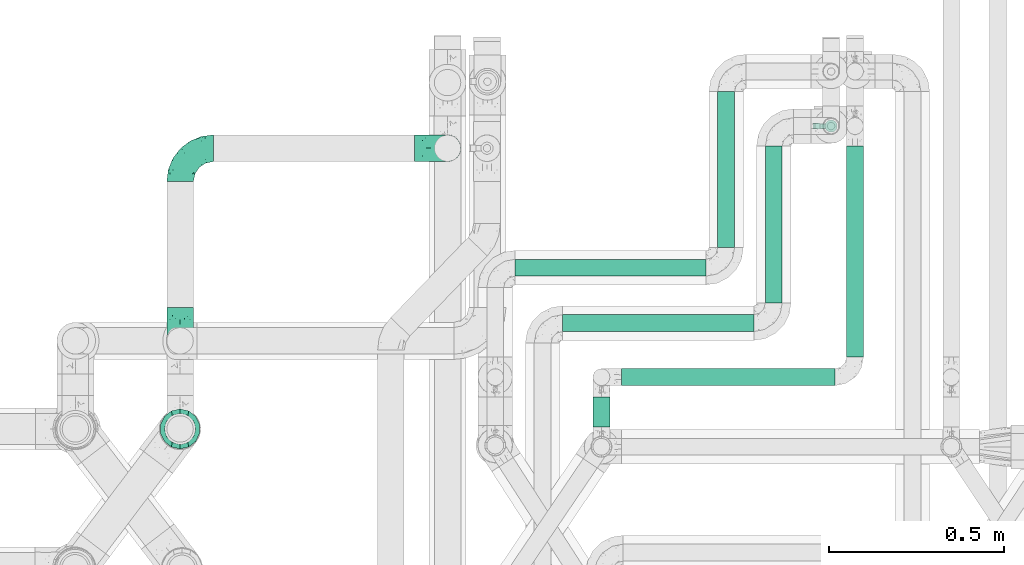
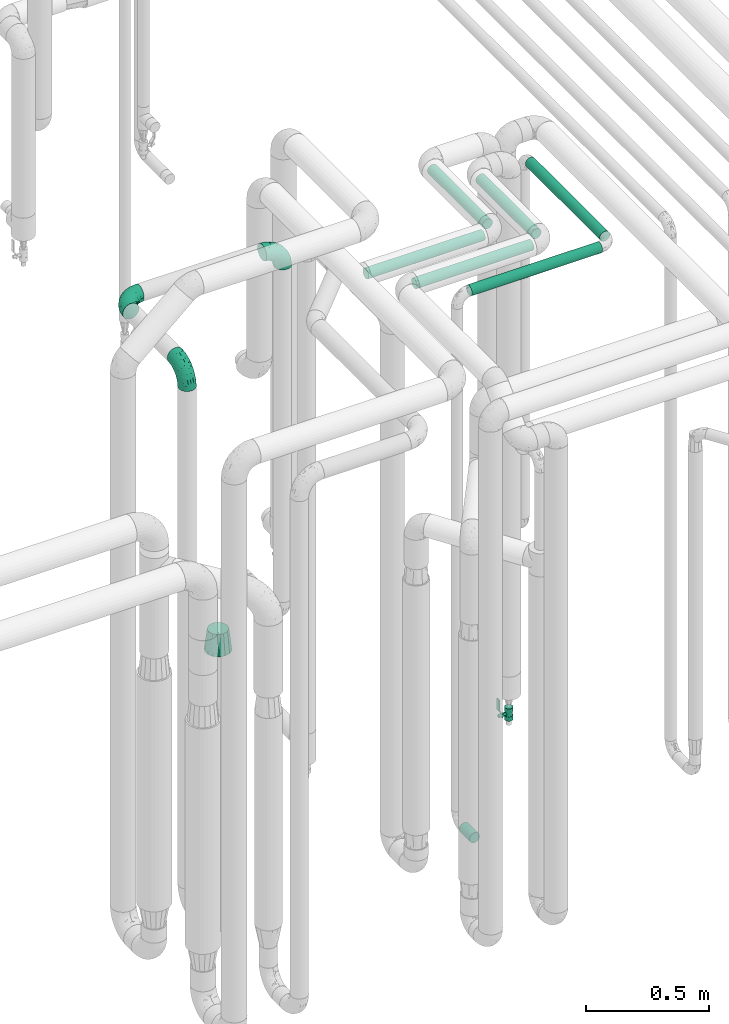
# One storey, part 673 of 827: 7 flow segments, 4 flow fittings, 1 flow controller.
"""IFC2X3 building model written with IfcOpenShell, lengths in millimetres."""

import ifcopenshell
import ifcopenshell.guid

model = None  # the IFC model being written
_history = None  # IfcOwnerHistory: only IFC2X3 demands one
_inside = {}  # id of a spatial element -> (the spatial element, [elements in it])
_under = {}  # id of a project, library or spatial element -> (it, [spatial elements below it])
_declared = {}  # id of a project -> (the project, [libraries it declares])
_typed = {}  # id of a type object -> (the type object, [elements of that type])
_made_of = {}  # id of a material, layer set ... -> (it, [elements and type objects made of it])


def new_model(schema):
    """Start an empty IFC model of exactly this schema.

    Asked for "IFC4X3", IfcOpenShell would pick the latest addendum, in which some entities
    have other attributes; the version numbers below select the first issue.
    IFC2X3 requires an IfcOwnerHistory on every rooted entity: one is made here for all.
    """
    global model, _history
    if schema == "IFC4X3":
        model = ifcopenshell.file(schema_version=(4, 3, 0, 0))
    else:
        model = ifcopenshell.file(schema=schema)
    _inside.clear()
    _under.clear()
    _declared.clear()
    _typed.clear()
    _made_of.clear()
    _history = None
    if model.schema == "IFC2X3":
        org = make("IfcOrganization", Name="unknown")
        user = make(
            "IfcPersonAndOrganization",
            ThePerson=make("IfcPerson", FamilyName="unknown"),
            TheOrganization=org,
        )
        app = make(
            "IfcApplication",
            ApplicationDeveloper=org,
            Version="unknown",
            ApplicationFullName="unknown",
            ApplicationIdentifier="unknown",
        )
        _history = make(
            "IfcOwnerHistory",
            OwningUser=user,
            OwningApplication=app,
            ChangeAction="ADDED",
            CreationDate=0,
        )
    return model


def make(cls, **values):
    """One entity of the class cls with the attributes given. An attribute that is None is left unset."""
    return model.create_entity(
        cls, **{name: value for name, value in values.items() if value is not None}
    )


def entity(cls, *values):
    """Any entity or typed value of the class cls, its attributes in the order of the schema. None: left unset."""
    e = model.create_entity(cls)
    for i, value in enumerate(values):
        if value is not None:
            e[i] = value
    return e


def rooted(cls, **values):
    """An entity with a GlobalId (a new one), such as an element, a storey or a relation."""
    return make(cls, GlobalId=ifcopenshell.guid.new(), OwnerHistory=_history, **values)


def si_unit(unit_type, name, prefix=None):
    """IfcSIUnit, for example si_unit("LENGTHUNIT", "METRE", prefix="MILLI")."""
    return make("IfcSIUnit", UnitType=unit_type, Prefix=prefix, Name=name)


def converted_unit(unit_type, name, factor, base, dimensions=None, offset=None):
    """IfcConversionBasedUnit, such as the inch: factor (a typed value) times the base unit."""
    return make(
        "IfcConversionBasedUnit"
        if offset is None
        else "IfcConversionBasedUnitWithOffset",
        ConversionOffset=offset,
        Dimensions=None
        if dimensions is None
        else entity("IfcDimensionalExponents", *dimensions),
        UnitType=unit_type,
        Name=name,
        ConversionFactor=make(
            "IfcMeasureWithUnit", ValueComponent=factor, UnitComponent=base
        ),
    )


def derived_unit(unit_type, elements):
    """IfcDerivedUnit: a product of units, each with its exponent."""
    return make(
        "IfcDerivedUnit",
        Elements=[
            make("IfcDerivedUnitElement", Unit=unit, Exponent=power)
            for unit, power in elements
        ],
        UnitType=unit_type,
    )


def assignment(units):
    """IfcUnitAssignment: the units of a project."""
    return None if units is None else make("IfcUnitAssignment", Units=units)


def point(xyz):
    """IfcCartesianPoint."""
    return None if xyz is None else make("IfcCartesianPoint", Coordinates=xyz)


def direction(xyz):
    """IfcDirection."""
    return None if xyz is None else make("IfcDirection", DirectionRatios=xyz)


def frame(location, z_axis=None, x_axis=None):
    """IfcAxis2Placement3D, a coordinate frame: its origin and axes. An axis left out is left unset."""
    return make(
        "IfcAxis2Placement3D",
        Location=point(location),
        Axis=direction(z_axis),
        RefDirection=direction(x_axis),
    )


def frame_2d(location, x_axis=None):
    """IfcAxis2Placement2D, a coordinate frame in the plane: its origin and x axis."""
    return make(
        "IfcAxis2Placement2D", Location=point(location), RefDirection=direction(x_axis)
    )


def origin():
    """The frame at (0, 0, 0) with its axes left unset."""
    return frame((0.0, 0.0, 0.0))


def origin_2d_with_axis():
    """The frame at (0, 0) in the plane with the x axis (1, 0) written out."""
    return frame_2d((0.0, 0.0), x_axis=(1.0, 0.0))


def place(relative_to, where):
    """IfcLocalPlacement: puts the frame where relative to a parent placement (None: the world)."""
    return make(
        "IfcLocalPlacement", PlacementRelTo=relative_to, RelativePlacement=where
    )


def context(
    kind, dimensions, precision=None, world=None, true_north=None, identifier=None
):
    """IfcGeometricRepresentationContext, for example the 3D "Model" context."""
    return make(
        "IfcGeometricRepresentationContext",
        ContextIdentifier=identifier,
        ContextType=kind,
        CoordinateSpaceDimension=dimensions,
        Precision=precision,
        WorldCoordinateSystem=world,
        TrueNorth=true_north,
    )


def subcontext(parent, identifier, kind, view, scale=None):
    """IfcGeometricRepresentationSubContext, for example "Body" below "Model"."""
    return make(
        "IfcGeometricRepresentationSubContext",
        ContextIdentifier=identifier,
        ContextType=kind,
        ParentContext=parent,
        TargetScale=scale,
        TargetView=view,
    )


def project(units=None, contexts=None):
    """IfcProject with its units and contexts."""
    return rooted(
        "IfcProject",
        Name="project",
        RepresentationContexts=contexts,
        UnitsInContext=assignment(units),
    )


def spatial(cls, under=None, at=None, **own):
    """A site, building, storey or space (cls), placed at a placement, below another one or the project."""
    s = rooted(cls, ObjectPlacement=at, **own)
    if under is not None:
        _under.setdefault(under.id(), (under, []))[1].append(s)
    return s


def polyline(points):
    """IfcPolyline through the points."""
    return make("IfcPolyline", Points=[point(p) for p in points])


def profile(cls, at=None, kind="AREA", **sizes):
    """A parametric profile (cls). Its sizes go by their IFC names, for example OverallWidth=200.0."""
    return make(cls, ProfileType=kind, Position=at, **sizes)


def circle(**sizes):
    """IfcCircleProfileDef."""
    return profile("IfcCircleProfileDef", **sizes)


def outline(outer, holes=None, kind="AREA"):
    """IfcArbitraryClosedProfileDef: a profile drawn as a closed curve; with holes, ...WithVoids."""
    if holes is None:
        return make("IfcArbitraryClosedProfileDef", ProfileType=kind, OuterCurve=outer)
    return make(
        "IfcArbitraryProfileDefWithVoids",
        ProfileType=kind,
        OuterCurve=outer,
        InnerCurves=holes,
    )


def extrude(swept, where, along, depth):
    """IfcExtrudedAreaSolid: the profile swept, set in the frame where, extruded along a direction by depth."""
    return make(
        "IfcExtrudedAreaSolid",
        SweptArea=swept,
        Position=where,
        ExtrudedDirection=direction(along),
        Depth=depth,
    )


def faces_of(points, faces, orient=None, outer=None):
    """IfcFace entities. A face is a list of loops; a loop is a list of indices into points, from 0.

    orient and outer hold one flag for each loop. By default every Orientation is true, the
    first loop of a face is its IfcFaceOuterBound and the others are IfcFaceBound.
    """
    made = []
    for i, loops in enumerate(faces):
        bounds = []
        for j, loop in enumerate(loops):
            is_outer = j == 0 if outer is None else outer[i][j]
            bounds.append(
                make(
                    "IfcFaceOuterBound" if is_outer else "IfcFaceBound",
                    Bound=make("IfcPolyLoop", Polygon=[points[k] for k in loop]),
                    Orientation=True if orient is None else orient[i][j],
                )
            )
        made.append(make("IfcFace", Bounds=bounds))
    return made


def faceted_brep(points, faces, orient=None, outer=None, voids=None):
    """IfcFacetedBrep: a solid bounded by flat faces; with voids (closed shells), ...WithVoids."""
    shared = [point(p) for p in points]
    hull = make("IfcClosedShell", CfsFaces=faces_of(shared, faces, orient, outer))
    if voids is None:
        return make("IfcFacetedBrep", Outer=hull)
    return make(
        "IfcFacetedBrepWithVoids",
        Outer=hull,
        Voids=[
            make(cls, CfsFaces=faces_of(shared, fs, o, b)) for cls, fs, o, b in voids
        ],
    )


def shape(context_of_items, identifier, shape_type, items):
    """IfcShapeRepresentation: the items that make up one representation, for example the "Body"."""
    return make(
        "IfcShapeRepresentation",
        ContextOfItems=context_of_items,
        RepresentationIdentifier=identifier,
        RepresentationType=shape_type,
        Items=items,
    )


def source(mapping_origin, context_of_items, identifier, shape_type, items):
    """IfcRepresentationMap: a shape defined once, which mapped items show again and again."""
    return make(
        "IfcRepresentationMap",
        MappingOrigin=mapping_origin,
        MappedRepresentation=shape(context_of_items, identifier, shape_type, items),
    )


def transform(
    local_origin,
    x_axis=None,
    y_axis=None,
    z_axis=None,
    scale=None,
    scale2=None,
    scale3=None,
    uniform=True,
):
    """IfcCartesianTransformationOperator3D, or its non-uniform kind. x_axis, y_axis, z_axis: its Axis1, 2, 3."""
    if uniform:
        return make(
            "IfcCartesianTransformationOperator3D",
            Axis1=direction(x_axis),
            Axis2=direction(y_axis),
            LocalOrigin=point(local_origin),
            Scale=scale,
            Axis3=direction(z_axis),
        )
    return make(
        "IfcCartesianTransformationOperator3DnonUniform",
        Axis1=direction(x_axis),
        Axis2=direction(y_axis),
        LocalOrigin=point(local_origin),
        Scale=scale,
        Axis3=direction(z_axis),
        Scale2=scale2,
        Scale3=scale3,
    )


def mapped(mapping_source, mapping_target):
    """IfcMappedItem: shows the shape of a source again, moved by a transform."""
    return make(
        "IfcMappedItem", MappingSource=mapping_source, MappingTarget=mapping_target
    )


def material(Name=None, Category=None):
    """IfcMaterial."""
    return make("IfcMaterial", Name=Name, Category=Category)


def material_list(materials):
    """IfcMaterialList."""
    return make("IfcMaterialList", Materials=materials)


def made_of(thing, what):
    """Note that an element or type object is made of a material, layer set ...; save() writes the relation."""
    if what is not None:
        _made_of.setdefault(what.id(), (what, []))[1].append(thing)
    return thing


def type_object(cls, material=None, **own):
    """A type object (cls), such as IfcWallType, which elements share."""
    return made_of(rooted(cls, **own), material)


def type_shapes(of_type, sources):
    """Give a type object the sources (RepresentationMaps) that its elements show as mapped items."""
    of_type.RepresentationMaps = sources


def element(
    cls,
    number,
    at=None,
    inside=None,
    cuts=None,
    type_object=None,
    material=None,
    context=None,
    identifier="Body",
    shape_type=None,
    held_by="IfcProductDefinitionShape",
    body=None,
    shapes=None,
    **own,
):
    """One element of the class cls, such as IfcWall. Its Tag is "e" and its number.

    at: its placement. inside: the storey or other place that contains it. cuts: it is an
    opening in that element (IfcRelVoidsElement). A single representation is given by context,
    identifier, shape_type and body (its items); several are given by shapes. held_by: the class
    of the entity that holds the representations. save() writes the other relations.
    """
    e = rooted(cls, Tag="e%d" % number, ObjectPlacement=at, **own)
    if body is not None:
        shapes = [shape(context, identifier, shape_type, body)]
    if shapes is not None:
        e.Representation = make(held_by, Representations=shapes)
    if inside is not None:
        _inside.setdefault(inside.id(), (inside, []))[1].append(e)
    if cuts is not None:
        rooted(
            "IfcRelVoidsElement", RelatingBuildingElement=cuts, RelatedOpeningElement=e
        )
    if type_object is not None:
        _typed.setdefault(type_object.id(), (type_object, []))[1].append(e)
    return made_of(e, material)


def aggregate(whole, parts):
    """IfcRelAggregates: a whole, such as a stair, and the parts it consists of."""
    return rooted("IfcRelAggregates", RelatingObject=whole, RelatedObjects=parts)


def save(model, path):
    """Write the relations noted so far, then the file.

    IfcRelAggregates (storeys below a building ...), IfcRelContainedInSpatialStructure (elements
    in a storey), IfcRelDefinesByType, IfcRelAssociatesMaterial and IfcRelDeclares: one each for
    every whole, place, type object, material and project.
    """
    for whole, parts in _under.values():
        aggregate(whole, parts)
    for where, things in _inside.values():
        rooted(
            "IfcRelContainedInSpatialStructure",
            RelatedElements=things,
            RelatingStructure=where,
        )
    for kind, things in _typed.values():
        rooted("IfcRelDefinesByType", RelatedObjects=things, RelatingType=kind)
    for what, things in _made_of.values():
        rooted("IfcRelAssociatesMaterial", RelatedObjects=things, RelatingMaterial=what)
    for by, libraries in _declared.values():
        rooted("IfcRelDeclares", RelatingContext=by, RelatedDefinitions=libraries)
    model.write(path)


model = new_model("IFC2X3")

# Units and contexts
model_context = context("Model", 3, precision=0.01, world=origin(), true_north=direction((6.12303176911189e-17, 1.0)))
body_context = subcontext(model_context, "Body", "Model", "MODEL_VIEW")
ifc_project = project(units=[si_unit("LENGTHUNIT", "METRE", prefix="MILLI"), si_unit("AREAUNIT", "SQUARE_METRE"), si_unit("VOLUMEUNIT", "CUBIC_METRE"), converted_unit("PLANEANGLEUNIT", "DEGREE", entity("IfcRatioMeasure", 0.0174532925199433), si_unit("PLANEANGLEUNIT", "RADIAN"), dimensions=[0, 0, 0, 0, 0, 0, 0]), si_unit("MASSUNIT", "GRAM", prefix="KILO"), derived_unit("MASSDENSITYUNIT", [(si_unit("MASSUNIT", "GRAM", prefix="KILO"), 1), (si_unit("LENGTHUNIT", "METRE"), -3)]), derived_unit("MOMENTOFINERTIAUNIT", [(si_unit("LENGTHUNIT", "METRE"), 4)]), si_unit("TIMEUNIT", "SECOND"), si_unit("FREQUENCYUNIT", "HERTZ"), si_unit("THERMODYNAMICTEMPERATUREUNIT", "DEGREE_CELSIUS"), derived_unit("THERMALTRANSMITTANCEUNIT", [(si_unit("MASSUNIT", "GRAM", prefix="KILO"), 1), (si_unit("THERMODYNAMICTEMPERATUREUNIT", "KELVIN"), -1), (si_unit("TIMEUNIT", "SECOND"), -3)]), derived_unit("VOLUMETRICFLOWRATEUNIT", [(si_unit("LENGTHUNIT", "METRE"), 3), (si_unit("TIMEUNIT", "SECOND"), -1)]), derived_unit("MASSFLOWRATEUNIT", [(si_unit("MASSUNIT", "GRAM", prefix="KILO"), 1), (si_unit("TIMEUNIT", "SECOND"), -1)]), derived_unit("ROTATIONALFREQUENCYUNIT", [(si_unit("TIMEUNIT", "SECOND"), -1)]), si_unit("ELECTRICCURRENTUNIT", "AMPERE"), si_unit("ELECTRICVOLTAGEUNIT", "VOLT"), si_unit("POWERUNIT", "WATT"), si_unit("FORCEUNIT", "NEWTON", prefix="KILO"), si_unit("ILLUMINANCEUNIT", "LUX"), si_unit("LUMINOUSFLUXUNIT", "LUMEN"), si_unit("LUMINOUSINTENSITYUNIT", "CANDELA"), derived_unit("USERDEFINED", [(si_unit("MASSUNIT", "GRAM", prefix="KILO"), -1), (si_unit("LENGTHUNIT", "METRE"), -2), (si_unit("TIMEUNIT", "SECOND"), 3), (si_unit("LUMINOUSFLUXUNIT", "LUMEN"), 1)]), derived_unit("LINEARVELOCITYUNIT", [(si_unit("LENGTHUNIT", "METRE"), 1), (si_unit("TIMEUNIT", "SECOND"), -1)]), si_unit("PRESSUREUNIT", "PASCAL"), derived_unit("USERDEFINED", [(si_unit("LENGTHUNIT", "METRE"), -2), (si_unit("MASSUNIT", "GRAM", prefix="KILO"), 1), (si_unit("TIMEUNIT", "SECOND"), -2)]), derived_unit("LINEARFORCEUNIT", [(si_unit("MASSUNIT", "GRAM", prefix="KILO"), 1), (si_unit("LENGTHUNIT", "METRE"), 1), (si_unit("TIMEUNIT", "SECOND"), -2), (si_unit("LENGTHUNIT", "METRE"), -1)]), derived_unit("PLANARFORCEUNIT", [(si_unit("MASSUNIT", "GRAM", prefix="KILO"), 1), (si_unit("LENGTHUNIT", "METRE"), 1), (si_unit("TIMEUNIT", "SECOND"), -2), (si_unit("LENGTHUNIT", "METRE"), -2)])], contexts=[model_context])

# Site, building, storey
site_placement = place(None, origin())
site = spatial("IfcSite", under=ifc_project, at=site_placement, CompositionType="ELEMENT")
building_placement = place(site_placement, origin())
building = spatial("IfcBuilding", under=site, at=building_placement, CompositionType="ELEMENT")
storey_placement = place(building_placement, frame((0.0, 0.0, 28200.0)))
storey = spatial("IfcBuildingStorey", under=building, at=storey_placement, Name="08", CompositionType="ELEMENT", Elevation=28200.0)

# Flow segments
pipe_segment_type = type_object("IfcPipeSegmentType", PredefinedType="NOTDEFINED")
flow_segment_1_placement = place(storey_placement, frame((47694.42, 14491.53, 2974.4)))
element("IfcFlowSegment", 1, at=flow_segment_1_placement, inside=storey, type_object=pipe_segment_type, context=body_context, shape_type="SweptSolid", body=[
    extrude(circle(Radius=24.0, at=origin_2d_with_axis()), frame((25.6, 0.0, 25.6), z_axis=(0.0, 1.0, 0.0), x_axis=(1.0, 0.0, 0.0)), (0.0, 0.0, 1.0), 602.710728474916),
])
flow_segment_2_placement = place(storey_placement, frame((47462.4, 14645.75, 2974.4)))
element("IfcFlowSegment", 2, at=flow_segment_2_placement, inside=storey, type_object=pipe_segment_type, context=body_context, shape_type="SweptSolid", body=[
    extrude(circle(Radius=24.0, at=origin_2d_with_axis()), frame((25.6, 0.0, 25.6), z_axis=(0.0, 1.0, 0.0), x_axis=(-1.0, 0.0, 0.0)), (0.0, 0.0, 1.0), 448.489185095073),
])
flow_segment_3_placement = place(storey_placement, frame((47326.4, 14804.03, 2974.4)))
element("IfcFlowSegment", 3, at=flow_segment_3_placement, inside=storey, type_object=pipe_segment_type, context=body_context, shape_type="SweptSolid", body=[
    extrude(circle(Radius=24.0, at=origin_2d_with_axis()), frame((25.6, 0.0, 25.6), z_axis=(0.0, 1.0, 0.0), x_axis=(-1.0, 0.0, 0.0)), (0.0, 0.0, 1.0), 446.000000000016),
])
flow_segment_4_placement = place(storey_placement, frame((46970.44, 14292.68, 374.4)))
element("IfcFlowSegment", 4, at=flow_segment_4_placement, inside=storey, type_object=pipe_segment_type, context=body_context, shape_type="SweptSolid", body=[
    extrude(circle(Radius=24.0, at=origin_2d_with_axis()), frame((25.6, 0.0, 25.6), z_axis=(0.0, 1.0, 0.0), x_axis=(-1.0, 0.0, 0.0)), (0.0, 0.0, 1.0), 84.8501728348417),
])
flow_segment_5_placement = place(storey_placement, frame((47053.03, 14408.93, 2974.4)))
element("IfcFlowSegment", 5, at=flow_segment_5_placement, inside=storey, type_object=pipe_segment_type, context=body_context, shape_type="SweptSolid", body=[
    extrude(circle(Radius=24.0, at=origin_2d_with_axis()), frame((0.0, 25.6, 25.6), z_axis=(1.0, 0.0, 0.0), x_axis=(0.0, 1.0, 0.0)), (0.0, 0.0, 1.0), 609.986534506505),
])
flow_segment_6_placement = place(storey_placement, frame((46885.0, 14563.15, 2974.4)))
element("IfcFlowSegment", 6, at=flow_segment_6_placement, inside=storey, type_object=pipe_segment_type, context=body_context, shape_type="SweptSolid", body=[
    extrude(circle(Radius=24.0, at=origin_2d_with_axis()), frame((0.0, 25.6, 25.6), z_axis=(1.0, 0.0, 0.0), x_axis=(0.0, 1.0, 0.0)), (0.0, 0.0, 1.0), 546.000000000006),
])
flow_segment_7_placement = place(storey_placement, frame((46749.79, 14721.43, 2974.4)))
element("IfcFlowSegment", 7, at=flow_segment_7_placement, inside=storey, type_object=pipe_segment_type, context=body_context, shape_type="SweptSolid", body=[
    extrude(circle(Radius=24.0, at=origin_2d_with_axis()), frame((0.0, 25.6, 25.6), z_axis=(1.0, 0.0, 0.0), x_axis=(0.0, 1.0, 0.0)), (0.0, 0.0, 1.0), 545.208916433662),
])

# Flow controller
ifc_material = material()
ifc_material_list = material_list([ifc_material, ifc_material, ifc_material, ifc_material, ifc_material])
valve_type = type_object("IfcValveType", PredefinedType="NOTDEFINED", material=ifc_material_list)
shared_shape_1 = source(origin(), body_context, "Body", "SweptSolid", [
    extrude(circle(Radius=17.5, at=origin_2d_with_axis()), frame((-30.5, 0.0, 0.0), z_axis=(1.0, 0.0, 0.0), x_axis=(0.0, 1.0, 0.0)), (0.0, 0.0, 1.0), 20.3333333333333),
    extrude(circle(Radius=16.0, at=origin_2d_with_axis()), frame((-10.17, 0.0, 0.0), z_axis=(1.0, 0.0, 0.0), x_axis=(0.0, 1.0, 0.0)), (0.0, 0.0, 1.0), 20.3333333333333),
    extrude(circle(Radius=17.5, at=origin_2d_with_axis()), frame((10.17, 0.0, 0.0), z_axis=(1.0, 0.0, 0.0), x_axis=(0.0, 1.0, 0.0)), (0.0, 0.0, 1.0), 20.3333333333333),
    extrude(outline(polyline([(-38.75, -5.0), (-38.75, -10.0), (-17.92, -10.0), (2.08, 5.0), (56.25, 5.0), (56.25, 10.0), (0.42, 10.0), (-19.58, -5.0), (-38.75, -5.0)])), frame((28.75, -8.75, 41.5), z_axis=(0.0, -1.0, 0.0), x_axis=(1.0, 0.0, 0.0)), (0.0, 0.0, -1.0), 17.5),
    extrude(circle(Radius=8.0, at=origin_2d_with_axis()), origin(), (0.0, 0.0, 1.0), 49.0),
])
type_shapes(valve_type, [shared_shape_1])
flow_controller_placement = place(storey_placement, frame((47651.75, 15151.24, 267.75), z_axis=(-1.0, 0.0, 0.0), x_axis=(0.0, 0.0, 1.0)))
element("IfcFlowController", 8, at=flow_controller_placement, inside=storey, type_object=valve_type, material=ifc_material, context=body_context, shape_type="MappedRepresentation", body=[
    mapped(shared_shape_1, transform((0.0, 0.0, 0.0), scale=1.0)),
])

# Flow fittings
pipe_fitting_type_1 = type_object("IfcPipeFittingType", Name="ADSK_1", PredefinedType="NOTDEFINED", material=ifc_material)
shared_shape_2 = source(origin(), body_context, "Body", "Brep", [
    faceted_brep([(-95.0, 19.02, -32.95), (-95.0, 9.85, -36.75), (-95.0, 0.0, -38.05), (-95.0, -9.85, -36.75), (-95.0, -19.03, -32.95), (-95.0, -26.91, -26.91), (-95.0, -32.95, -19.03), (-95.0, -36.75, -9.85), (-95.0, -38.05, 0.0), (-95.0, -36.75, 9.85), (-95.0, -32.95, 19.02), (-95.0, -26.91, 26.91), (-95.0, -19.03, 32.95), (-95.0, -9.85, 36.75), (-95.0, 0.0, 38.05), (-95.0, 9.85, 36.75), (-95.0, 19.02, 32.95), (-95.0, 26.91, 26.91), (-95.0, 32.95, 19.02), (-95.0, 36.75, 9.85), (-95.0, 38.05, 0.0), (-95.0, 36.75, -9.85), (-95.0, 32.95, -19.03), (-95.0, 26.91, -26.91), (0.0, 95.0, -38.05), (-9.85, 95.0, -36.75), (-19.02, 95.0, -32.95), (-26.91, 95.0, -26.91), (-32.95, 95.0, -19.03), (-36.75, 95.0, -9.85), (-38.05, 95.0, 0.0), (-36.75, 95.0, 9.85), (-32.95, 95.0, 19.02), (-26.91, 95.0, 26.91), (-19.02, 95.0, 32.95), (-9.85, 95.0, 36.75), (0.0, 95.0, 38.05), (9.85, 95.0, 36.75), (19.03, 95.0, 32.95), (26.91, 95.0, 26.91), (32.95, 95.0, 19.02), (36.75, 95.0, 9.85), (38.05, 95.0, 0.0), (36.75, 95.0, -9.85), (32.95, 95.0, -19.03), (26.91, 95.0, -26.91), (19.03, 95.0, -32.95), (9.85, 95.0, -36.75), (-7.99, -4.96, 6.3), (-0.92, 0.92, 0.0), (4.62, 8.1, 8.01), (-76.19, -35.57, 0.0), (-64.32, -32.32, 12.43), (20.51, 62.45, 28.68), (-60.56, -33.52, 0.0), (-70.4, -13.47, 34.42), (-39.61, -5.88, 32.32), (-49.6, 2.07, 37.1), (-70.34, -28.81, 21.71), (14.64, 40.81, 26.5), (5.88, 39.61, 32.32), (3.59, 20.77, 25.31), (-40.45, 68.06, 16.75), (-62.45, -20.51, 28.68), (-44.52, -26.87, 0.0), (-28.47, -20.22, 0.0), (-26.43, -17.83, 8.75), (-76.1, 39.63, 10.76), (-72.74, 37.58, 18.19), (-60.35, 46.18, 14.61), (-13.4, 13.4, 32.12), (-20.77, -3.59, 25.31), (-14.66, 81.47, 35.56), (-6.22, 71.26, 37.92), (-57.5, 42.48, 22.79), (-15.0, 34.74, 37.7), (-27.1, 12.08, 36.05), (-9.2, 28.81, 35.63), (-79.98, 23.7, 30.95), (-73.68, -4.3, 37.48), (-30.74, 21.67, 37.97), (-62.36, 47.59, 6.79), (-72.71, 32.83, 24.69), (-67.42, 7.02, 37.95), (-32.13, 75.27, 24.51), (-43.46, 51.47, 26.26), (-24.98, 73.15, 31.29), (20.59, 41.28, 19.85), (7.79, 16.09, 15.86), (-73.21, 42.39, 0.0), (-54.73, 54.73, 0.0), (-73.44, 15.79, 35.79), (-5.94, 4.32, 20.43), (28.81, 70.34, 21.71), (32.32, 64.32, 12.43), (-53.59, 26.2, 35.09), (-52.02, 19.31, 37.21), (21.38, 33.53, 10.34), (26.87, 44.52, 0.0), (-48.28, 12.14, 38.05), (4.3, 73.68, 37.48), (-44.08, -25.52, 12.79), (-41.28, -20.59, 19.85), (35.57, 76.19, 0.0), (-47.26, 54.3, 20.18), (-47.4, 61.99, 8.58), (-42.39, 73.21, 0.0), (-39.67, 78.86, 7.21), (-45.69, 36.84, 33.11), (-32.83, 50.13, 33.35), (13.47, 70.4, 34.42), (-18.25, 63.73, 36.07), (-40.63, -13.75, 27.22), (-16.63, 46.37, 37.95), (-53.47, 38.79, 28.59), (-26.07, 48.54, 36.15), (-34.51, 34.51, 36.86), (-2.07, 49.6, 37.1), (-22.79, -10.49, 19.23), (-61.73, 28.67, 31.87), (9.65, 14.7, 0.0), (20.22, 28.47, 0.0), (33.52, 60.56, 0.0), (-11.42, -5.44, 13.25), (-14.7, -9.65, 0.0), (-81.47, 14.66, -35.56), (-62.45, -20.51, -28.68), (-71.26, 6.22, -37.92), (-75.27, 32.13, -24.51), (-73.15, 24.98, -31.29), (13.47, 70.4, -34.42), (5.88, 39.61, -32.32), (-2.07, 49.6, -37.1), (-78.86, 39.67, -7.21), (-70.4, -13.47, -34.42), (-39.61, -5.88, -32.32), (-61.99, 47.4, -8.58), (32.32, 64.32, -12.43), (28.81, 70.34, -21.71), (-63.73, 18.25, -36.07), (-50.13, 32.83, -33.35), (4.3, 73.68, -37.48), (-7.02, 67.42, -37.95), (-39.63, 76.1, -10.76), (-46.18, 60.35, -14.61), (-47.59, 62.36, -6.79), (-64.32, -32.32, -12.43), (-26.2, 53.59, -35.09), (-15.79, 73.44, -35.79), (-19.31, 52.02, -37.21), (-37.58, 72.74, -18.19), (-70.34, -28.81, -21.71), (-42.48, 57.5, -22.79), (-38.79, 53.47, -28.59), (-51.47, 43.46, -26.26), (-32.83, 72.71, -24.69), (-46.37, 16.63, -37.95), (-73.68, -4.3, -37.48), (-41.28, -20.59, -19.85), (-44.08, -25.52, -12.79), (13.75, 40.63, -27.22), (20.51, 62.45, -28.68), (-68.06, 40.45, -16.75), (-54.3, 47.26, -20.18), (-12.14, 48.28, -38.05), (-21.67, 30.74, -37.97), (-36.84, 45.69, -33.11), (-11.42, -5.44, -13.25), (7.79, 16.09, -15.86), (4.62, 8.1, -8.01), (-23.7, 79.98, -30.95), (-26.43, -17.83, -8.75), (-7.99, -4.96, -6.3), (-40.81, -14.64, -26.5), (-20.77, -3.59, -25.31), (-34.74, 15.0, -37.7), (-12.08, 27.1, -36.05), (-28.81, 9.2, -35.63), (-22.79, -10.49, -19.23), (21.38, 33.53, -10.34), (20.59, 41.28, -19.85), (-48.54, 26.07, -36.15), (-49.6, 2.07, -37.1), (-13.4, 13.4, -32.12), (3.59, 20.77, -25.31), (-28.67, 61.73, -31.87), (-34.51, 34.51, -36.86), (-5.94, 4.32, -20.43)], [[[0, 1, 2, 3, 4, 5, 6, 7, 8, 9, 10, 11, 12, 13, 14, 15, 16, 17, 18, 19, 20, 21, 22, 23]], [[24, 25, 26, 27, 28, 29, 30, 31, 32, 33, 34, 35, 36, 37, 38, 39, 40, 41, 42, 43, 44, 45, 46, 47]], [[48, 49, 50]], [[51, 52, 9]], [[53, 39, 38]], [[9, 52, 10]], [[54, 52, 51]], [[55, 56, 57]], [[11, 10, 58]], [[59, 60, 61]], [[32, 31, 62]], [[63, 12, 11]], [[63, 55, 12]], [[64, 65, 66]], [[67, 68, 69]], [[70, 56, 71]], [[35, 72, 73]], [[69, 68, 74]], [[75, 76, 77]], [[16, 78, 17]], [[13, 79, 14]], [[76, 75, 80]], [[67, 69, 81]], [[18, 17, 82]], [[14, 79, 83]], [[20, 19, 67]], [[84, 85, 86]], [[87, 61, 88]], [[89, 81, 90]], [[18, 82, 68]], [[15, 91, 16]], [[14, 83, 15]], [[71, 92, 61]], [[17, 78, 82]], [[93, 87, 94]], [[95, 91, 96]], [[97, 98, 94]], [[86, 72, 34]], [[96, 99, 80]], [[37, 36, 100]], [[40, 39, 93]], [[40, 94, 41]], [[64, 66, 101]], [[93, 94, 40]], [[58, 102, 63]], [[94, 103, 41]], [[94, 87, 97]], [[104, 69, 74]], [[34, 33, 86]], [[105, 69, 104]], [[52, 58, 10]], [[106, 107, 30]], [[108, 109, 85]], [[105, 106, 90]], [[53, 110, 60]], [[86, 111, 72]], [[86, 109, 111]], [[33, 84, 86]], [[12, 55, 13]], [[112, 56, 63]], [[110, 38, 37]], [[34, 72, 35]], [[36, 35, 73]], [[111, 113, 73]], [[105, 107, 106]], [[110, 53, 38]], [[74, 114, 85]], [[91, 15, 83]], [[105, 90, 81]], [[107, 62, 31]], [[33, 32, 84]], [[115, 109, 116]], [[111, 115, 113]], [[100, 73, 117]], [[56, 55, 63]], [[79, 55, 57]], [[102, 118, 112]], [[56, 70, 76]], [[100, 110, 37]], [[117, 77, 60]], [[117, 60, 110]], [[60, 70, 61]], [[58, 52, 101]], [[63, 11, 58]], [[39, 53, 93]], [[87, 93, 53]], [[96, 91, 83]], [[78, 91, 119]], [[32, 62, 84]], [[84, 62, 104]], [[86, 85, 109]], [[85, 114, 108]], [[80, 113, 116]], [[117, 73, 113]], [[80, 116, 96]], [[80, 57, 76]], [[71, 112, 118]], [[61, 87, 59]], [[62, 107, 105]], [[97, 120, 121]], [[70, 71, 61]], [[71, 118, 92]], [[73, 100, 36]], [[110, 100, 117]], [[55, 79, 13]], [[83, 79, 57]], [[96, 83, 99]], [[116, 108, 95]], [[50, 97, 88]], [[97, 87, 88]], [[50, 49, 120]], [[122, 94, 98]], [[89, 20, 67]], [[105, 81, 69]], [[89, 67, 81]], [[68, 19, 18]], [[68, 67, 19]], [[74, 68, 82]], [[114, 82, 119]], [[74, 85, 104]], [[82, 114, 74]], [[114, 119, 108]], [[95, 108, 119]], [[116, 109, 108]], [[123, 48, 50]], [[97, 50, 120]], [[123, 50, 88]], [[91, 95, 119]], [[116, 95, 96]], [[84, 104, 85]], [[104, 62, 105]], [[83, 57, 99]], [[57, 80, 99]], [[66, 48, 123]], [[66, 124, 48]], [[118, 66, 123]], [[124, 66, 65]], [[66, 118, 101]], [[54, 64, 52]], [[124, 49, 48]], [[30, 107, 31]], [[91, 78, 16]], [[82, 78, 119]], [[56, 76, 57]], [[77, 76, 70]], [[60, 77, 70]], [[77, 117, 75]], [[117, 113, 75]], [[113, 80, 75]], [[9, 8, 51]], [[103, 94, 122]], [[103, 42, 41]], [[73, 72, 111]], [[113, 115, 116]], [[111, 109, 115]], [[102, 112, 63]], [[71, 56, 112]], [[118, 102, 101]], [[92, 123, 88]], [[123, 92, 118]], [[61, 92, 88]], [[87, 53, 59]], [[60, 59, 53]], [[97, 121, 98]], [[58, 101, 102]], [[64, 101, 52]], [[125, 1, 0]], [[126, 5, 4]], [[2, 1, 127]], [[1, 125, 127]], [[128, 129, 23]], [[130, 131, 132]], [[89, 133, 20]], [[126, 134, 135]], [[136, 89, 90]], [[137, 138, 44]], [[139, 129, 140]], [[24, 141, 142]], [[143, 144, 145]], [[125, 129, 139]], [[6, 146, 7]], [[147, 148, 149]], [[146, 51, 7]], [[143, 150, 144]], [[146, 6, 151]], [[152, 153, 154]], [[126, 4, 134]], [[0, 23, 129]], [[28, 155, 150]], [[43, 42, 103]], [[54, 146, 64]], [[139, 156, 127]], [[157, 3, 2]], [[151, 158, 159]], [[160, 131, 161]], [[22, 21, 162]], [[136, 144, 163]], [[149, 164, 165]], [[24, 142, 25]], [[166, 140, 154]], [[154, 129, 128]], [[143, 30, 29]], [[167, 168, 169]], [[155, 28, 27]], [[26, 170, 27]], [[171, 167, 172]], [[26, 25, 148]], [[27, 170, 155]], [[173, 135, 174]], [[144, 150, 152]], [[175, 176, 177]], [[24, 47, 141]], [[45, 161, 46]], [[148, 25, 142]], [[176, 175, 165]], [[64, 159, 171]], [[138, 45, 44]], [[130, 46, 161]], [[137, 44, 43]], [[178, 159, 158]], [[137, 103, 122]], [[163, 144, 152]], [[136, 133, 89]], [[103, 137, 43]], [[6, 5, 151]], [[178, 158, 173]], [[134, 4, 3]], [[178, 173, 174]], [[137, 98, 179]], [[145, 90, 106]], [[138, 180, 161]], [[46, 130, 47]], [[136, 90, 145]], [[133, 162, 21]], [[23, 22, 128]], [[139, 140, 181]], [[139, 181, 156]], [[157, 127, 182]], [[157, 134, 3]], [[182, 177, 135]], [[182, 135, 134]], [[135, 183, 174]], [[131, 130, 161]], [[141, 130, 132]], [[160, 180, 184]], [[131, 183, 176]], [[5, 126, 151]], [[158, 151, 126]], [[180, 138, 137]], [[161, 45, 138]], [[149, 148, 142]], [[170, 148, 185]], [[22, 162, 128]], [[128, 162, 163]], [[129, 154, 140]], [[154, 153, 166]], [[165, 156, 186]], [[182, 127, 156]], [[165, 186, 149]], [[165, 132, 176]], [[131, 184, 183]], [[187, 167, 178]], [[184, 168, 187]], [[167, 169, 172]], [[184, 180, 168]], [[174, 183, 184]], [[127, 157, 2]], [[134, 157, 182]], [[130, 141, 47]], [[142, 141, 132]], [[149, 142, 164]], [[186, 166, 147]], [[180, 179, 168]], [[169, 179, 120]], [[137, 179, 180]], [[179, 121, 120]], [[106, 30, 143]], [[136, 145, 144]], [[106, 143, 145]], [[150, 29, 28]], [[150, 143, 29]], [[152, 150, 155]], [[153, 155, 185]], [[152, 154, 163]], [[155, 153, 152]], [[153, 185, 166]], [[147, 166, 185]], [[186, 140, 166]], [[169, 120, 49]], [[169, 49, 172]], [[179, 169, 168]], [[148, 147, 185]], [[186, 147, 149]], [[128, 163, 154]], [[163, 162, 136]], [[142, 132, 164]], [[132, 165, 164]], [[171, 124, 65]], [[124, 171, 172]], [[64, 146, 159]], [[171, 159, 178]], [[171, 65, 64]], [[172, 49, 124]], [[162, 133, 136]], [[20, 133, 21]], [[148, 170, 26]], [[155, 170, 185]], [[131, 176, 132]], [[177, 176, 183]], [[135, 177, 183]], [[177, 182, 175]], [[182, 156, 175]], [[156, 165, 175]], [[51, 146, 54]], [[51, 8, 7]], [[129, 125, 0]], [[127, 125, 139]], [[140, 186, 181]], [[156, 181, 186]], [[158, 126, 173]], [[135, 173, 126]], [[187, 178, 174]], [[171, 178, 167]], [[184, 187, 174]], [[167, 187, 168]], [[180, 160, 161]], [[184, 131, 160]], [[98, 137, 122]], [[98, 121, 179]], [[151, 159, 146]]]),
])
type_shapes(pipe_fitting_type_1, [shared_shape_2])
for number, where, z_axis, x_axis, name in (
    (9, (45793.07, 14538.08, 3000.0), (-1.0, 0.0, 0.0), (0.0, 0.0, 1.0), "ADSK_1"),
    (10, (45793.07, 15088.04, 3000.0), (0.0, 0.0, 1.0), (-1.0, 0.0, 0.0), "ADSK_1"),
    (11, (46556.64, 15088.04, 3000.0), (0.0, -1.0, 0.0), (0.0, 0.0, 1.0), "ADSK_1"),
):
    element("IfcFlowFitting", number, at=place(storey_placement, frame(where, z_axis=z_axis, x_axis=x_axis)), inside=storey, type_object=pipe_fitting_type_1, material=ifc_material, Name=name, ObjectType="ADSK_1", context=body_context, shape_type="MappedRepresentation", body=[
        mapped(shared_shape_2, transform((0.0, 0.0, 0.0), scale=1.0)),
    ])
pipe_fitting_type_2 = type_object("IfcPipeFittingType", Name="ADSK_1", PredefinedType="NOTDEFINED", material=ifc_material)
shared_shape_3 = source(origin(), body_context, "Body", "Brep", [
    faceted_brep([(102.0, -30.36, 30.36), (102.0, -38.49, 22.23), (102.0, -41.47, 11.11), (102.0, -44.45, 0.0), (102.0, -41.47, -11.11), (102.0, -38.49, -22.22), (102.0, -30.36, -30.36), (102.0, -22.23, -38.49), (102.0, -11.11, -41.47), (102.0, 0.0, -44.45), (102.0, 11.11, -41.47), (102.0, 22.22, -38.49), (102.0, 30.36, -30.36), (102.0, 38.49, -22.22), (102.0, 41.47, -11.11), (102.0, 44.45, 0.0), (102.0, 41.47, 11.11), (102.0, 38.49, 22.23), (102.0, 30.36, 30.36), (102.0, 22.22, 38.49), (102.0, 11.11, 41.47), (102.0, 0.0, 44.45), (102.0, -11.11, 41.47), (102.0, -22.23, 38.49), (0.0, 24.17, 50.2), (0.0, 35.63, 44.68), (0.0, 43.56, 34.74), (0.0, 51.49, 24.8), (0.0, 54.32, 12.4), (0.0, 57.15, 0.0), (0.0, 54.32, -12.4), (0.0, 51.49, -24.8), (0.0, 43.56, -34.74), (0.0, 35.63, -44.68), (0.0, 24.17, -50.2), (0.0, 12.72, -55.72), (0.0, 0.0, -55.72), (0.0, -12.72, -55.72), (0.0, -24.17, -50.2), (0.0, -35.63, -44.68), (0.0, -43.56, -34.74), (0.0, -51.49, -24.8), (0.0, -54.32, -12.4), (0.0, -57.15, 0.0), (0.0, -54.32, 12.4), (0.0, -51.49, 24.8), (0.0, -43.56, 34.74), (0.0, -35.63, 44.68), (0.0, -24.17, 50.2), (0.0, -12.72, 55.72), (0.0, 0.0, 55.72), (0.0, 12.72, 55.72)], [[[0, 1, 2, 3, 4, 5, 6, 7, 8, 9, 10, 11, 12, 13, 14, 15, 16, 17, 18, 19, 20, 21, 22, 23]], [[24, 25, 26, 27, 28, 29, 30, 31, 32, 33, 34, 35, 36, 37, 38, 39, 40, 41, 42, 43, 44, 45, 46, 47, 48, 49, 50, 51]], [[14, 31, 30]], [[42, 3, 43]], [[32, 31, 13]], [[13, 31, 14]], [[34, 10, 35]], [[3, 42, 4]], [[12, 11, 33]], [[9, 37, 36, 35]], [[7, 39, 38]], [[39, 7, 6]], [[38, 8, 7]], [[34, 33, 11]], [[10, 9, 35]], [[40, 5, 41]], [[12, 33, 32]], [[15, 30, 29]], [[38, 37, 8]], [[15, 14, 30]], [[41, 5, 4]], [[5, 40, 6]], [[13, 12, 32]], [[10, 34, 11]], [[37, 9, 8]], [[40, 39, 6]], [[42, 41, 4]], [[2, 45, 44]], [[28, 15, 29]], [[46, 45, 1]], [[1, 45, 2]], [[48, 22, 49]], [[15, 28, 16]], [[0, 23, 47]], [[21, 51, 50, 49]], [[19, 25, 24]], [[25, 19, 18]], [[24, 20, 19]], [[48, 47, 23]], [[22, 21, 49]], [[26, 17, 27]], [[0, 47, 46]], [[3, 44, 43]], [[24, 51, 20]], [[3, 2, 44]], [[27, 17, 16]], [[17, 26, 18]], [[1, 0, 46]], [[22, 48, 23]], [[51, 21, 20]], [[26, 25, 18]], [[28, 27, 16]]]),
])
type_shapes(pipe_fitting_type_2, [shared_shape_3])
flow_fitting_placement = place(storey_placement, frame((45793.07, 14286.62, 1758.0), z_axis=(1.0, 0.0, 0.0), x_axis=(0.0, 0.0, 1.0)))
element("IfcFlowFitting", 12, at=flow_fitting_placement, inside=storey, type_object=pipe_fitting_type_2, material=ifc_material, Name="ADSK_1", ObjectType="ADSK_1", context=body_context, shape_type="MappedRepresentation", body=[
    mapped(shared_shape_3, transform((0.0, 0.0, 0.0), scale=1.0)),
])

save(model, "model.ifc")
